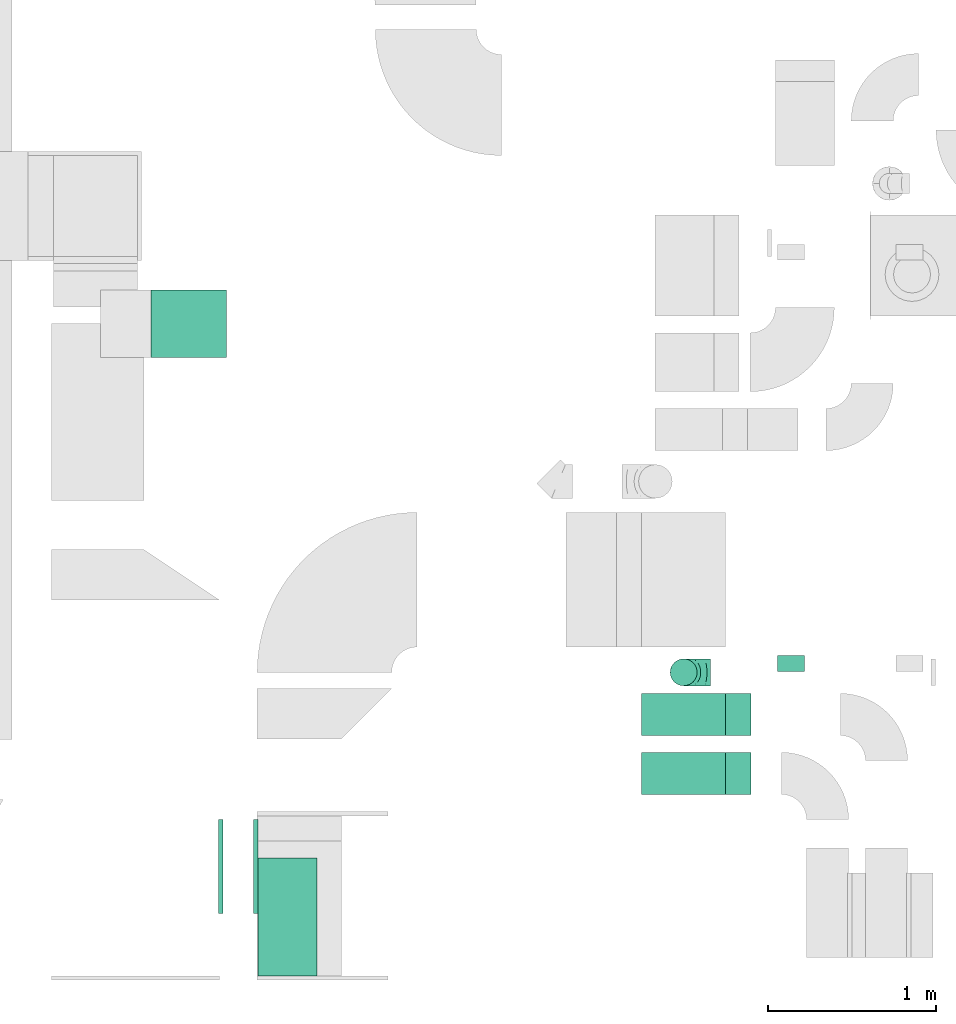
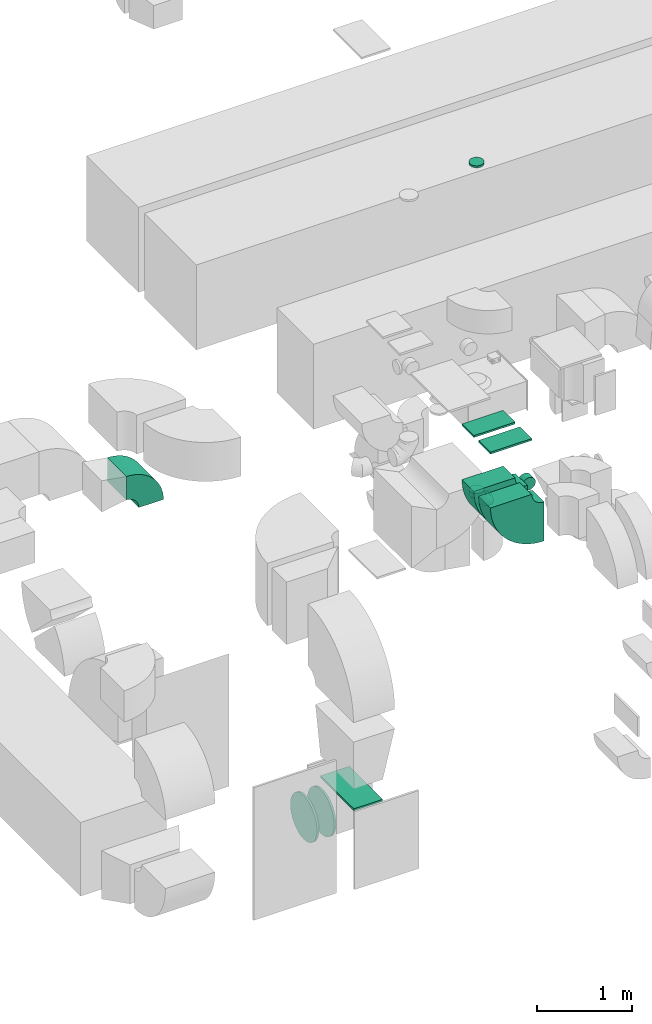
# One storey, part 7 of 59: 11 flow fittings.
"""IFC2X3 building model written with IfcOpenShell, lengths in millimetres."""

import ifcopenshell
import ifcopenshell.guid

model = None  # the IFC model being written
_history = None  # IfcOwnerHistory: only IFC2X3 demands one
_inside = {}  # id of a spatial element -> (the spatial element, [elements in it])
_under = {}  # id of a project, library or spatial element -> (it, [spatial elements below it])
_declared = {}  # id of a project -> (the project, [libraries it declares])
_typed = {}  # id of a type object -> (the type object, [elements of that type])
_made_of = {}  # id of a material, layer set ... -> (it, [elements and type objects made of it])


def new_model(schema):
    """Start an empty IFC model of exactly this schema.

    Asked for "IFC4X3", IfcOpenShell would pick the latest addendum, in which some entities
    have other attributes; the version numbers below select the first issue.
    IFC2X3 requires an IfcOwnerHistory on every rooted entity: one is made here for all.
    """
    global model, _history
    if schema == "IFC4X3":
        model = ifcopenshell.file(schema_version=(4, 3, 0, 0))
    else:
        model = ifcopenshell.file(schema=schema)
    _inside.clear()
    _under.clear()
    _declared.clear()
    _typed.clear()
    _made_of.clear()
    _history = None
    if model.schema == "IFC2X3":
        org = make("IfcOrganization", Name="unknown")
        user = make(
            "IfcPersonAndOrganization",
            ThePerson=make("IfcPerson", FamilyName="unknown"),
            TheOrganization=org,
        )
        app = make(
            "IfcApplication",
            ApplicationDeveloper=org,
            Version="unknown",
            ApplicationFullName="unknown",
            ApplicationIdentifier="unknown",
        )
        _history = make(
            "IfcOwnerHistory",
            OwningUser=user,
            OwningApplication=app,
            ChangeAction="ADDED",
            CreationDate=0,
        )
    return model


def make(cls, **values):
    """One entity of the class cls with the attributes given. An attribute that is None is left unset."""
    return model.create_entity(
        cls, **{name: value for name, value in values.items() if value is not None}
    )


def entity(cls, *values):
    """Any entity or typed value of the class cls, its attributes in the order of the schema. None: left unset."""
    e = model.create_entity(cls)
    for i, value in enumerate(values):
        if value is not None:
            e[i] = value
    return e


def rooted(cls, **values):
    """An entity with a GlobalId (a new one), such as an element, a storey or a relation."""
    return make(cls, GlobalId=ifcopenshell.guid.new(), OwnerHistory=_history, **values)


def si_unit(unit_type, name, prefix=None):
    """IfcSIUnit, for example si_unit("LENGTHUNIT", "METRE", prefix="MILLI")."""
    return make("IfcSIUnit", UnitType=unit_type, Prefix=prefix, Name=name)


def converted_unit(unit_type, name, factor, base, dimensions=None, offset=None):
    """IfcConversionBasedUnit, such as the inch: factor (a typed value) times the base unit."""
    return make(
        "IfcConversionBasedUnit"
        if offset is None
        else "IfcConversionBasedUnitWithOffset",
        ConversionOffset=offset,
        Dimensions=None
        if dimensions is None
        else entity("IfcDimensionalExponents", *dimensions),
        UnitType=unit_type,
        Name=name,
        ConversionFactor=make(
            "IfcMeasureWithUnit", ValueComponent=factor, UnitComponent=base
        ),
    )


def derived_unit(unit_type, elements):
    """IfcDerivedUnit: a product of units, each with its exponent."""
    return make(
        "IfcDerivedUnit",
        Elements=[
            make("IfcDerivedUnitElement", Unit=unit, Exponent=power)
            for unit, power in elements
        ],
        UnitType=unit_type,
    )


def assignment(units):
    """IfcUnitAssignment: the units of a project."""
    return None if units is None else make("IfcUnitAssignment", Units=units)


def point(xyz):
    """IfcCartesianPoint."""
    return None if xyz is None else make("IfcCartesianPoint", Coordinates=xyz)


def direction(xyz):
    """IfcDirection."""
    return None if xyz is None else make("IfcDirection", DirectionRatios=xyz)


def frame(location, z_axis=None, x_axis=None):
    """IfcAxis2Placement3D, a coordinate frame: its origin and axes. An axis left out is left unset."""
    return make(
        "IfcAxis2Placement3D",
        Location=point(location),
        Axis=direction(z_axis),
        RefDirection=direction(x_axis),
    )


def frame_2d(location, x_axis=None):
    """IfcAxis2Placement2D, a coordinate frame in the plane: its origin and x axis."""
    return make(
        "IfcAxis2Placement2D", Location=point(location), RefDirection=direction(x_axis)
    )


def origin():
    """The frame at (0, 0, 0) with its axes left unset."""
    return frame((0.0, 0.0, 0.0))


def origin_2d_with_axis():
    """The frame at (0, 0) in the plane with the x axis (1, 0) written out."""
    return frame_2d((0.0, 0.0), x_axis=(1.0, 0.0))


def place(relative_to, where):
    """IfcLocalPlacement: puts the frame where relative to a parent placement (None: the world)."""
    return make(
        "IfcLocalPlacement", PlacementRelTo=relative_to, RelativePlacement=where
    )


def context(
    kind, dimensions, precision=None, world=None, true_north=None, identifier=None
):
    """IfcGeometricRepresentationContext, for example the 3D "Model" context."""
    return make(
        "IfcGeometricRepresentationContext",
        ContextIdentifier=identifier,
        ContextType=kind,
        CoordinateSpaceDimension=dimensions,
        Precision=precision,
        WorldCoordinateSystem=world,
        TrueNorth=true_north,
    )


def subcontext(parent, identifier, kind, view, scale=None):
    """IfcGeometricRepresentationSubContext, for example "Body" below "Model"."""
    return make(
        "IfcGeometricRepresentationSubContext",
        ContextIdentifier=identifier,
        ContextType=kind,
        ParentContext=parent,
        TargetScale=scale,
        TargetView=view,
    )


def project(units=None, contexts=None):
    """IfcProject with its units and contexts."""
    return rooted(
        "IfcProject",
        Name="project",
        RepresentationContexts=contexts,
        UnitsInContext=assignment(units),
    )


def spatial(cls, under=None, at=None, **own):
    """A site, building, storey or space (cls), placed at a placement, below another one or the project."""
    s = rooted(cls, ObjectPlacement=at, **own)
    if under is not None:
        _under.setdefault(under.id(), (under, []))[1].append(s)
    return s


def polyline(points):
    """IfcPolyline through the points."""
    return make("IfcPolyline", Points=[point(p) for p in points])


def circle_curve(where, radius):
    """IfcCircle in the frame where."""
    return make("IfcCircle", Position=where, Radius=radius)


def parameter(value):
    """IfcParameterValue: where a trimmed curve begins or ends, as a parameter of its basis curve."""
    return model.create_entity("IfcParameterValue", value)


def trimmed(basis, trim1, trim2, sense, master):
    """IfcTrimmedCurve: the piece of a basis curve between two trims."""
    return make(
        "IfcTrimmedCurve",
        BasisCurve=basis,
        Trim1=trim1,
        Trim2=trim2,
        SenseAgreement=sense,
        MasterRepresentation=master,
    )


def segment(curve, same_sense, transition):
    """IfcCompositeCurveSegment."""
    return make(
        "IfcCompositeCurveSegment",
        Transition=transition,
        SameSense=same_sense,
        ParentCurve=curve,
    )


def composite_curve(segments, self_intersect=None):
    """IfcCompositeCurve: segments joined end to end."""
    return make("IfcCompositeCurve", Segments=segments, SelfIntersect=self_intersect)


def profile(cls, at=None, kind="AREA", **sizes):
    """A parametric profile (cls). Its sizes go by their IFC names, for example OverallWidth=200.0."""
    return make(cls, ProfileType=kind, Position=at, **sizes)


def rectangle(**sizes):
    """IfcRectangleProfileDef."""
    return profile("IfcRectangleProfileDef", **sizes)


def circle(**sizes):
    """IfcCircleProfileDef."""
    return profile("IfcCircleProfileDef", **sizes)


def outline(outer, holes=None, kind="AREA"):
    """IfcArbitraryClosedProfileDef: a profile drawn as a closed curve; with holes, ...WithVoids."""
    if holes is None:
        return make("IfcArbitraryClosedProfileDef", ProfileType=kind, OuterCurve=outer)
    return make(
        "IfcArbitraryProfileDefWithVoids",
        ProfileType=kind,
        OuterCurve=outer,
        InnerCurves=holes,
    )


def extrude(swept, where, along, depth):
    """IfcExtrudedAreaSolid: the profile swept, set in the frame where, extruded along a direction by depth."""
    return make(
        "IfcExtrudedAreaSolid",
        SweptArea=swept,
        Position=where,
        ExtrudedDirection=direction(along),
        Depth=depth,
    )


def faces_of(points, faces, orient=None, outer=None):
    """IfcFace entities. A face is a list of loops; a loop is a list of indices into points, from 0.

    orient and outer hold one flag for each loop. By default every Orientation is true, the
    first loop of a face is its IfcFaceOuterBound and the others are IfcFaceBound.
    """
    made = []
    for i, loops in enumerate(faces):
        bounds = []
        for j, loop in enumerate(loops):
            is_outer = j == 0 if outer is None else outer[i][j]
            bounds.append(
                make(
                    "IfcFaceOuterBound" if is_outer else "IfcFaceBound",
                    Bound=make("IfcPolyLoop", Polygon=[points[k] for k in loop]),
                    Orientation=True if orient is None else orient[i][j],
                )
            )
        made.append(make("IfcFace", Bounds=bounds))
    return made


def faceted_brep(points, faces, orient=None, outer=None, voids=None):
    """IfcFacetedBrep: a solid bounded by flat faces; with voids (closed shells), ...WithVoids."""
    shared = [point(p) for p in points]
    hull = make("IfcClosedShell", CfsFaces=faces_of(shared, faces, orient, outer))
    if voids is None:
        return make("IfcFacetedBrep", Outer=hull)
    return make(
        "IfcFacetedBrepWithVoids",
        Outer=hull,
        Voids=[
            make(cls, CfsFaces=faces_of(shared, fs, o, b)) for cls, fs, o, b in voids
        ],
    )


def shape(context_of_items, identifier, shape_type, items):
    """IfcShapeRepresentation: the items that make up one representation, for example the "Body"."""
    return make(
        "IfcShapeRepresentation",
        ContextOfItems=context_of_items,
        RepresentationIdentifier=identifier,
        RepresentationType=shape_type,
        Items=items,
    )


def source(mapping_origin, context_of_items, identifier, shape_type, items):
    """IfcRepresentationMap: a shape defined once, which mapped items show again and again."""
    return make(
        "IfcRepresentationMap",
        MappingOrigin=mapping_origin,
        MappedRepresentation=shape(context_of_items, identifier, shape_type, items),
    )


def transform(
    local_origin,
    x_axis=None,
    y_axis=None,
    z_axis=None,
    scale=None,
    scale2=None,
    scale3=None,
    uniform=True,
):
    """IfcCartesianTransformationOperator3D, or its non-uniform kind. x_axis, y_axis, z_axis: its Axis1, 2, 3."""
    if uniform:
        return make(
            "IfcCartesianTransformationOperator3D",
            Axis1=direction(x_axis),
            Axis2=direction(y_axis),
            LocalOrigin=point(local_origin),
            Scale=scale,
            Axis3=direction(z_axis),
        )
    return make(
        "IfcCartesianTransformationOperator3DnonUniform",
        Axis1=direction(x_axis),
        Axis2=direction(y_axis),
        LocalOrigin=point(local_origin),
        Scale=scale,
        Axis3=direction(z_axis),
        Scale2=scale2,
        Scale3=scale3,
    )


def mapped(mapping_source, mapping_target):
    """IfcMappedItem: shows the shape of a source again, moved by a transform."""
    return make(
        "IfcMappedItem", MappingSource=mapping_source, MappingTarget=mapping_target
    )


def material(Name=None, Category=None):
    """IfcMaterial."""
    return make("IfcMaterial", Name=Name, Category=Category)


def made_of(thing, what):
    """Note that an element or type object is made of a material, layer set ...; save() writes the relation."""
    if what is not None:
        _made_of.setdefault(what.id(), (what, []))[1].append(thing)
    return thing


def type_object(cls, material=None, **own):
    """A type object (cls), such as IfcWallType, which elements share."""
    return made_of(rooted(cls, **own), material)


def type_shapes(of_type, sources):
    """Give a type object the sources (RepresentationMaps) that its elements show as mapped items."""
    of_type.RepresentationMaps = sources


def element(
    cls,
    number,
    at=None,
    inside=None,
    cuts=None,
    type_object=None,
    material=None,
    context=None,
    identifier="Body",
    shape_type=None,
    held_by="IfcProductDefinitionShape",
    body=None,
    shapes=None,
    **own,
):
    """One element of the class cls, such as IfcWall. Its Tag is "e" and its number.

    at: its placement. inside: the storey or other place that contains it. cuts: it is an
    opening in that element (IfcRelVoidsElement). A single representation is given by context,
    identifier, shape_type and body (its items); several are given by shapes. held_by: the class
    of the entity that holds the representations. save() writes the other relations.
    """
    e = rooted(cls, Tag="e%d" % number, ObjectPlacement=at, **own)
    if body is not None:
        shapes = [shape(context, identifier, shape_type, body)]
    if shapes is not None:
        e.Representation = make(held_by, Representations=shapes)
    if inside is not None:
        _inside.setdefault(inside.id(), (inside, []))[1].append(e)
    if cuts is not None:
        rooted(
            "IfcRelVoidsElement", RelatingBuildingElement=cuts, RelatedOpeningElement=e
        )
    if type_object is not None:
        _typed.setdefault(type_object.id(), (type_object, []))[1].append(e)
    return made_of(e, material)


def aggregate(whole, parts):
    """IfcRelAggregates: a whole, such as a stair, and the parts it consists of."""
    return rooted("IfcRelAggregates", RelatingObject=whole, RelatedObjects=parts)


def save(model, path):
    """Write the relations noted so far, then the file.

    IfcRelAggregates (storeys below a building ...), IfcRelContainedInSpatialStructure (elements
    in a storey), IfcRelDefinesByType, IfcRelAssociatesMaterial and IfcRelDeclares: one each for
    every whole, place, type object, material and project.
    """
    for whole, parts in _under.values():
        aggregate(whole, parts)
    for where, things in _inside.values():
        rooted(
            "IfcRelContainedInSpatialStructure",
            RelatedElements=things,
            RelatingStructure=where,
        )
    for kind, things in _typed.values():
        rooted("IfcRelDefinesByType", RelatedObjects=things, RelatingType=kind)
    for what, things in _made_of.values():
        rooted("IfcRelAssociatesMaterial", RelatedObjects=things, RelatingMaterial=what)
    for by, libraries in _declared.values():
        rooted("IfcRelDeclares", RelatingContext=by, RelatedDefinitions=libraries)
    model.write(path)


model = new_model("IFC2X3")

# Units and contexts
model_context = context("Model", 3, precision=0.01, world=origin(), true_north=direction((6.12303176911189e-17, 1.0)))
body_context = subcontext(model_context, "Body", "Model", "MODEL_VIEW")
ifc_project = project(units=[si_unit("LENGTHUNIT", "METRE", prefix="MILLI"), si_unit("AREAUNIT", "SQUARE_METRE"), si_unit("VOLUMEUNIT", "CUBIC_METRE"), converted_unit("PLANEANGLEUNIT", "DEGREE", entity("IfcRatioMeasure", 0.0174532925199433), si_unit("PLANEANGLEUNIT", "RADIAN"), dimensions=[0, 0, 0, 0, 0, 0, 0]), si_unit("MASSUNIT", "GRAM", prefix="KILO"), derived_unit("MASSDENSITYUNIT", [(si_unit("MASSUNIT", "GRAM", prefix="KILO"), 1), (si_unit("LENGTHUNIT", "METRE"), -3)]), derived_unit("MOMENTOFINERTIAUNIT", [(si_unit("LENGTHUNIT", "METRE"), 4)]), si_unit("TIMEUNIT", "SECOND"), si_unit("FREQUENCYUNIT", "HERTZ"), si_unit("THERMODYNAMICTEMPERATUREUNIT", "DEGREE_CELSIUS"), derived_unit("THERMALTRANSMITTANCEUNIT", [(si_unit("MASSUNIT", "GRAM", prefix="KILO"), 1), (si_unit("THERMODYNAMICTEMPERATUREUNIT", "KELVIN"), -1), (si_unit("TIMEUNIT", "SECOND"), -3)]), derived_unit("VOLUMETRICFLOWRATEUNIT", [(si_unit("LENGTHUNIT", "METRE"), 3), (si_unit("TIMEUNIT", "SECOND"), -1)]), derived_unit("MASSFLOWRATEUNIT", [(si_unit("MASSUNIT", "GRAM", prefix="KILO"), 1), (si_unit("TIMEUNIT", "SECOND"), -1)]), derived_unit("ROTATIONALFREQUENCYUNIT", [(si_unit("TIMEUNIT", "SECOND"), -1)]), si_unit("ELECTRICCURRENTUNIT", "AMPERE"), si_unit("ELECTRICVOLTAGEUNIT", "VOLT"), si_unit("POWERUNIT", "WATT"), si_unit("FORCEUNIT", "NEWTON", prefix="KILO"), si_unit("ILLUMINANCEUNIT", "LUX"), si_unit("LUMINOUSFLUXUNIT", "LUMEN"), si_unit("LUMINOUSINTENSITYUNIT", "CANDELA"), derived_unit("USERDEFINED", [(si_unit("MASSUNIT", "GRAM", prefix="KILO"), -1), (si_unit("LENGTHUNIT", "METRE"), -2), (si_unit("TIMEUNIT", "SECOND"), 3), (si_unit("LUMINOUSFLUXUNIT", "LUMEN"), 1)]), derived_unit("LINEARVELOCITYUNIT", [(si_unit("LENGTHUNIT", "METRE"), 1), (si_unit("TIMEUNIT", "SECOND"), -1)]), si_unit("PRESSUREUNIT", "PASCAL"), derived_unit("USERDEFINED", [(si_unit("LENGTHUNIT", "METRE"), -2), (si_unit("MASSUNIT", "GRAM", prefix="KILO"), 1), (si_unit("TIMEUNIT", "SECOND"), -2)]), derived_unit("LINEARFORCEUNIT", [(si_unit("MASSUNIT", "GRAM", prefix="KILO"), 1), (si_unit("LENGTHUNIT", "METRE"), 1), (si_unit("TIMEUNIT", "SECOND"), -2), (si_unit("LENGTHUNIT", "METRE"), -1)]), derived_unit("PLANARFORCEUNIT", [(si_unit("MASSUNIT", "GRAM", prefix="KILO"), 1), (si_unit("LENGTHUNIT", "METRE"), 1), (si_unit("TIMEUNIT", "SECOND"), -2), (si_unit("LENGTHUNIT", "METRE"), -2)])], contexts=[model_context])

# Site, building, storey
site_placement = place(None, origin())
site = spatial("IfcSite", under=ifc_project, at=site_placement, CompositionType="ELEMENT")
building_placement = place(site_placement, origin())
building = spatial("IfcBuilding", under=site, at=building_placement, CompositionType="ELEMENT")
storey_placement = place(building_placement, frame((0.0, 0.0, 28200.0)))
storey = spatial("IfcBuildingStorey", under=building, at=storey_placement, CompositionType="ELEMENT", Elevation=28200.0)

# Flow fittings
ifc_material = material()
duct_fitting_type_1 = type_object("IfcDuctFittingType", PredefinedType="NOTDEFINED", material=ifc_material)
shared_shape_1 = source(origin(), body_context, "Body", "SweptSolid", [
    extrude(circle(Radius=79.9999999999994, at=origin_2d_with_axis()), frame((0.0, 0.0, 0.0), z_axis=(1.0, 0.0, 0.0), x_axis=(0.0, 1.0, 0.0)), (0.0, 0.0, 1.0), 25.0000000000018),
])
type_shapes(duct_fitting_type_1, [shared_shape_1])
flow_fitting_1_placement = place(storey_placement, frame((27824.64, 9627.84, 7540.0), z_axis=(1.0, 0.0, 0.0), x_axis=(0.0, 0.0, 1.0)))
element("IfcFlowFitting", 1, at=flow_fitting_1_placement, inside=storey, type_object=duct_fitting_type_1, material=ifc_material, context=body_context, shape_type="MappedRepresentation", body=[
    mapped(shared_shape_1, transform((0.0, 0.0, 0.0), scale=1.0)),
])
duct_fitting_type_2 = type_object("IfcDuctFittingType", PredefinedType="NOTDEFINED", material=ifc_material)
shared_shape_2 = source(origin(), body_context, "Body", "SweptSolid", [
    extrude(rectangle(XDim=26.0960000000872, YDim=350.0, at=origin_2d_with_axis()), frame((6.95, 0.0, -350.0)), (0.0, 0.0, 1.0), 700.0),
])
type_shapes(duct_fitting_type_2, [shared_shape_2])
flow_fitting_2_placement = place(storey_placement, frame((25470.29, 8174.6, 1225.0), z_axis=(0.0, -1.0, 0.0), x_axis=(0.0, 0.0, 1.0)))
element("IfcFlowFitting", 2, at=flow_fitting_2_placement, inside=storey, type_object=duct_fitting_type_2, material=ifc_material, context=body_context, shape_type="MappedRepresentation", body=[
    mapped(shared_shape_2, transform((0.0, 0.0, 0.0), scale=1.0)),
])
duct_fitting_type_3 = type_object("IfcDuctFittingType", PredefinedType="NOTDEFINED", material=ifc_material)
shared_shape_3 = source(origin(), body_context, "Body", "SweptSolid", [
    extrude(rectangle(XDim=24.9999999999999, YDim=250.0, at=origin_2d_with_axis()), frame((12.5, 0.0, -250.0)), (0.0, 0.0, 1.0), 500.0),
])
type_shapes(duct_fitting_type_3, [shared_shape_3])
for number, where, z_axis, x_axis in (
    (3, (27824.64, 9377.5, 4340.0), (1.0, 0.0, 0.0), (0.0, 0.0, 1.0)),
    (4, (27824.64, 9027.5, 4340.0), (1.0, 0.0, 0.0), (0.0, 0.0, 1.0)),
):
    element("IfcFlowFitting", number, at=place(storey_placement, frame(where, z_axis=z_axis, x_axis=x_axis)), inside=storey, type_object=duct_fitting_type_3, material=ifc_material, context=body_context, shape_type="MappedRepresentation", body=[
        mapped(shared_shape_3, transform((0.0, 0.0, 0.0), scale=1.0)),
    ])
duct_fitting_type_4 = type_object("IfcDuctFittingType", PredefinedType="NOTDEFINED", material=ifc_material)
shared_shape_4 = source(origin(), body_context, "Body", "Brep", [
    faceted_brep([(-160.0, 0.0, -80.0), (-160.0, -20.71, -77.27), (-160.0, -40.0, -69.28), (-160.0, -56.57, -56.57), (-160.0, -69.28, -40.0), (-160.0, -77.27, -20.71), (-160.0, -80.0, 0.0), (-160.0, -77.27, 20.71), (-160.0, -69.28, 40.0), (-160.0, -56.57, 56.57), (-160.0, -40.0, 69.28), (-160.0, -20.71, 77.27), (-160.0, 0.0, 80.0), (-160.0, 20.71, 77.27), (-160.0, 40.0, 69.28), (-160.0, 56.57, 56.57), (-160.0, 69.28, 40.0), (-160.0, 77.27, 20.71), (-160.0, 80.0, 0.0), (-160.0, 77.27, -20.71), (-160.0, 69.28, -40.0), (-160.0, 56.57, -56.57), (-160.0, 40.0, -69.28), (-160.0, 20.71, -77.27), (-122.68, 20.71, 77.27), (-127.85, 40.0, 69.28), (-117.13, 0.0, 80.0), (-132.29, 56.57, 56.57), (-137.83, 77.27, 20.71), (-138.56, 80.0, 0.0), (-135.69, 69.28, 40.0), (-135.69, 69.28, -40.0), (-132.29, 56.57, -56.57), (-137.83, 77.27, -20.71), (-122.68, 20.71, -77.27), (-117.13, 0.0, -80.0), (-127.85, 40.0, -69.28), (-111.58, -20.71, -77.27), (-106.41, -40.0, -69.28), (-101.97, -56.57, -56.57), (-98.56, -69.28, -40.0), (-96.42, -77.27, -20.71), (-95.69, -80.0, 0.0), (-96.42, -77.27, 20.71), (-98.56, -69.28, 40.0), (-101.97, -56.57, 56.57), (-106.41, -40.0, 69.28), (-111.58, -20.71, 77.27), (-58.03, 58.03, 77.27), (-72.15, 72.15, 69.28), (-42.87, 42.87, 80.0), (-84.28, 84.28, 56.57), (-93.59, 93.59, 40.0), (-99.44, 99.44, 20.71), (-101.44, 101.44, 0.0), (-99.44, 99.44, -20.71), (-93.59, 93.59, -40.0), (-84.28, 84.28, -56.57), (-58.03, 58.03, -77.27), (-42.87, 42.87, -80.0), (-72.15, 72.15, -69.28), (-27.71, 27.71, -77.27), (-13.59, 13.59, -69.28), (-1.46, 1.46, -56.57), (7.85, -7.85, -40.0), (13.7, -13.7, -20.71), (15.69, -15.69, 0.0), (13.7, -13.7, 20.71), (7.85, -7.85, 40.0), (-1.46, 1.46, 56.57), (-13.59, 13.59, 69.28), (-27.71, 27.71, 77.27), (-20.71, 122.68, 77.27), (-40.0, 127.85, 69.28), (0.0, 117.13, 80.0), (-56.57, 132.29, 56.57), (-69.28, 135.69, 40.0), (-77.27, 137.83, 20.71), (-80.0, 138.56, 0.0), (-77.27, 137.83, -20.71), (-69.28, 135.69, -40.0), (-56.57, 132.29, -56.57), (-20.71, 122.68, -77.27), (0.0, 117.13, -80.0), (-40.0, 127.85, -69.28), (20.71, 111.58, -77.27), (40.0, 106.41, -69.28), (56.57, 101.97, -56.57), (69.28, 98.56, -40.0), (77.27, 96.42, -20.71), (80.0, 95.69, 0.0), (77.27, 96.42, 20.71), (69.28, 98.56, 40.0), (56.57, 101.97, 56.57), (40.0, 106.41, 69.28), (20.71, 111.58, 77.27), (-20.71, 160.0, -77.27), (-40.0, 160.0, -69.28), (-56.57, 160.0, -56.57), (-69.28, 160.0, -40.0), (-77.27, 160.0, -20.71), (-80.0, 160.0, 0.0), (-77.27, 160.0, 20.71), (-69.28, 160.0, 40.0), (-56.57, 160.0, 56.57), (-40.0, 160.0, 69.28), (-20.71, 160.0, 77.27), (0.0, 160.0, 80.0), (20.71, 160.0, 77.27), (40.0, 160.0, 69.28), (56.57, 160.0, 56.57), (69.28, 160.0, 40.0), (77.27, 160.0, 20.71), (80.0, 160.0, 0.0), (77.27, 160.0, -20.71), (69.28, 160.0, -40.0), (56.57, 160.0, -56.57), (40.0, 160.0, -69.28), (20.71, 160.0, -77.27), (0.0, 160.0, -80.0)], [[[0, 1, 2, 3, 4, 5, 6, 7, 8, 9, 10, 11, 12, 13, 14, 15, 16, 17, 18, 19, 20, 21, 22, 23]], [[24, 25, 14, 13]], [[26, 24, 13, 12]], [[14, 25, 27, 15]], [[28, 29, 18, 17]], [[30, 28, 17, 16]], [[15, 27, 30, 16]], [[20, 31, 32, 21]], [[33, 31, 20, 19]], [[18, 29, 33, 19]], [[34, 35, 0, 23]], [[36, 34, 23, 22]], [[32, 36, 22, 21]], [[1, 0, 35, 37]], [[2, 1, 37, 38]], [[3, 2, 38, 39]], [[5, 4, 40, 41]], [[6, 5, 41, 42]], [[39, 40, 4, 3]], [[6, 42, 43, 7]], [[7, 43, 44, 8]], [[8, 44, 45, 9]], [[9, 45, 46, 10]], [[10, 46, 47, 11]], [[26, 12, 11, 47]], [[48, 49, 25, 24]], [[50, 48, 24, 26]], [[27, 25, 49, 51]], [[52, 53, 28, 30]], [[51, 52, 30, 27]], [[29, 28, 53, 54]], [[55, 56, 31, 33]], [[54, 55, 33, 29]], [[32, 31, 56, 57]], [[58, 59, 35, 34]], [[60, 58, 34, 36]], [[57, 60, 36, 32]], [[37, 35, 59, 61]], [[38, 37, 61, 62]], [[39, 38, 62, 63]], [[41, 40, 64, 65]], [[42, 41, 65, 66]], [[63, 64, 40, 39]], [[43, 42, 66, 67]], [[44, 43, 67, 68]], [[68, 69, 45, 44]], [[46, 45, 69, 70]], [[47, 46, 70, 71]], [[26, 47, 71, 50]], [[72, 73, 49, 48]], [[74, 72, 48, 50]], [[51, 49, 73, 75]], [[76, 77, 53, 52]], [[75, 76, 52, 51]], [[54, 53, 77, 78]], [[79, 80, 56, 55]], [[78, 79, 55, 54]], [[57, 56, 80, 81]], [[82, 83, 59, 58]], [[84, 82, 58, 60]], [[81, 84, 60, 57]], [[61, 59, 83, 85]], [[62, 61, 85, 86]], [[63, 62, 86, 87]], [[65, 64, 88, 89]], [[66, 65, 89, 90]], [[87, 88, 64, 63]], [[67, 66, 90, 91]], [[68, 67, 91, 92]], [[92, 93, 69, 68]], [[70, 69, 93, 94]], [[71, 70, 94, 95]], [[50, 71, 95, 74]], [[96, 97, 98, 99, 100, 101, 102, 103, 104, 105, 106, 107, 108, 109, 110, 111, 112, 113, 114, 115, 116, 117, 118, 119]], [[72, 74, 107, 106]], [[73, 72, 106, 105]], [[75, 73, 105, 104]], [[77, 76, 103, 102]], [[78, 77, 102, 101]], [[75, 104, 103, 76]], [[78, 101, 100, 79]], [[79, 100, 99, 80]], [[80, 99, 98, 81]], [[84, 97, 96, 82]], [[82, 96, 119, 83]], [[84, 81, 98, 97]], [[118, 117, 86, 85]], [[119, 118, 85, 83]], [[116, 87, 86, 117]], [[88, 115, 114, 89]], [[89, 114, 113, 90]], [[115, 88, 87, 116]], [[112, 111, 92, 91]], [[113, 112, 91, 90]], [[111, 110, 93, 92]], [[95, 94, 109, 108]], [[74, 95, 108, 107]], [[110, 109, 94, 93]]]),
])
type_shapes(duct_fitting_type_4, [shared_shape_4])
flow_fitting_3_placement = place(storey_placement, frame((27824.64, 9627.84, 3205.01), z_axis=(0.0, -1.0, 0.0), x_axis=(0.0, 0.0, -1.0)))
element("IfcFlowFitting", 5, at=flow_fitting_3_placement, inside=storey, type_object=duct_fitting_type_4, material=ifc_material, context=body_context, shape_type="MappedRepresentation", body=[
    mapped(shared_shape_4, transform((0.0, 0.0, 0.0), scale=1.0)),
])
duct_fitting_type_5 = type_object("IfcDuctFittingType", PredefinedType="NOTDEFINED", material=ifc_material)
shared_shape_5 = source(origin(), body_context, "Body", "Brep", [
    faceted_brep([(20.0, 20.71, -77.27), (20.0, 40.0, -69.28), (20.0, 56.57, -56.57), (20.0, 69.28, -40.0), (20.0, 77.27, -20.71), (20.0, 80.0, 0.0), (20.0, 77.27, 20.71), (20.0, 69.28, 40.0), (20.0, 56.57, 56.57), (20.0, 40.0, 69.28), (20.0, 20.71, 77.27), (20.0, 0.0, 80.0), (20.0, -20.71, 77.27), (20.0, -40.0, 69.28), (20.0, -56.57, 56.57), (20.0, -69.28, 40.0), (20.0, -77.27, 20.71), (20.0, -80.0, 0.0), (20.0, -77.27, -20.71), (20.0, -69.28, -40.0), (20.0, -56.57, -56.57), (20.0, -40.0, -69.28), (20.0, -20.71, -77.27), (20.0, 0.0, -80.0), (0.0, 0.0, 80.0), (0.0, 20.71, 77.27), (-73.9, 20.71, 77.27), (-73.9, 0.0, 80.0), (0.0, 40.0, 69.28), (-73.9, 40.0, 69.28), (0.0, 56.57, 56.57), (-73.9, 56.57, 56.57), (0.0, 69.28, 40.0), (0.0, 77.27, 20.71), (-73.9, 77.27, 20.71), (-73.9, 69.28, 40.0), (0.0, 80.0, 0.0), (-73.9, 80.0, 0.0), (0.0, 77.27, -20.71), (-73.9, 77.27, -20.71), (0.0, 69.28, -40.0), (-73.9, 69.28, -40.0), (0.0, 56.57, -56.57), (-73.9, 56.57, -56.57), (0.0, 40.0, -69.28), (0.0, 20.71, -77.27), (-73.9, 20.71, -77.27), (-73.9, 40.0, -69.28), (0.0, 0.0, -80.0), (-73.9, 0.0, -80.0), (0.0, -20.71, -77.27), (-73.9, -20.71, -77.27), (0.0, -40.0, -69.28), (-73.9, -40.0, -69.28), (0.0, -56.57, -56.57), (-73.9, -56.57, -56.57), (0.0, -69.28, -40.0), (0.0, -77.27, -20.71), (-73.9, -77.27, -20.71), (-73.9, -69.28, -40.0), (0.0, -80.0, 0.0), (-73.9, -80.0, 0.0), (0.0, -77.27, 20.71), (-73.9, -77.27, 20.71), (0.0, -69.28, 40.0), (-73.9, -69.28, 40.0), (0.0, -56.57, 56.57), (-73.9, -56.57, 56.57), (0.0, -40.0, 69.28), (0.0, -20.71, 77.27), (-73.9, -20.71, 77.27), (-73.9, -40.0, 69.28)], [[[0, 1, 2, 3, 4, 5, 6, 7, 8, 9, 10, 11, 12, 13, 14, 15, 16, 17, 18, 19, 20, 21, 22, 23]], [[24, 11, 10, 25, 26, 27]], [[25, 10, 9, 28, 29, 26]], [[28, 9, 8, 30, 31, 29]], [[32, 7, 6, 33, 34, 35]], [[33, 6, 5, 36, 37, 34]], [[30, 8, 7, 32, 35, 31]], [[36, 5, 4, 38, 39, 37]], [[38, 4, 3, 40, 41, 39]], [[40, 3, 2, 42, 43, 41]], [[44, 1, 0, 45, 46, 47]], [[45, 0, 23, 48, 49, 46]], [[42, 2, 1, 44, 47, 43]], [[48, 23, 22, 50, 51, 49]], [[50, 22, 21, 52, 53, 51]], [[52, 21, 20, 54, 55, 53]], [[56, 19, 18, 57, 58, 59]], [[57, 18, 17, 60, 61, 58]], [[54, 20, 19, 56, 59, 55]], [[60, 17, 16, 62, 63, 61]], [[62, 16, 15, 64, 65, 63]], [[64, 15, 14, 66, 67, 65]], [[68, 13, 12, 69, 70, 71]], [[69, 12, 11, 24, 27, 70]], [[66, 14, 13, 68, 71, 67]], [[49, 51, 53, 55, 59, 58, 61, 63, 65, 67, 71, 70, 27, 26, 29, 31, 35, 34, 37, 39, 41, 43, 47, 46]]]),
])
type_shapes(duct_fitting_type_5, [shared_shape_5])
flow_fitting_4_placement = place(storey_placement, frame((28463.36, 9707.84, 3205.01), z_axis=(0.0, 0.0, -1.0), x_axis=(0.0, 1.0, 0.0)))
element("IfcFlowFitting", 6, at=flow_fitting_4_placement, inside=storey, type_object=duct_fitting_type_5, material=ifc_material, context=body_context, shape_type="MappedRepresentation", body=[
    mapped(shared_shape_5, transform((0.0, 0.0, 0.0), scale=1.0)),
])
duct_fitting_type_6 = type_object("IfcDuctFittingType", PredefinedType="NOTDEFINED", material=ifc_material)
shared_shape_6 = source(origin(), body_context, "Body", "Brep", [
    faceted_brep([(20.0, -107.15, -258.69), (20.0, -54.63, -274.62), (20.0, 0.0, -280.0), (20.0, 54.63, -274.62), (20.0, 107.15, -258.69), (20.0, 155.56, -232.81), (20.0, 197.99, -197.99), (20.0, 232.81, -155.56), (20.0, 258.69, -107.15), (20.0, 274.62, -54.63), (20.0, 280.0, 0.0), (20.0, 274.62, 54.63), (20.0, 258.69, 107.15), (20.0, 232.81, 155.56), (20.0, 197.99, 197.99), (20.0, 155.56, 232.81), (20.0, 107.15, 258.69), (20.0, 54.63, 274.62), (20.0, 0.0, 280.0), (20.0, -54.63, 274.62), (20.0, -107.15, 258.69), (20.0, -155.56, 232.81), (20.0, -197.99, 197.99), (20.0, -232.81, 155.56), (20.0, -258.69, 107.15), (20.0, -274.62, 54.63), (20.0, -280.0, 0.0), (20.0, -274.62, -54.63), (20.0, -258.69, -107.15), (20.0, -232.81, -155.56), (20.0, -197.99, -197.99), (20.0, -155.56, -232.81), (0.0, 0.0, 280.0), (0.0, -36.28, 276.43), (0.0, -54.63, 274.62), (-6.1, -27.31, 277.31), (-6.1, 0.0, 280.0), (-6.1, -54.63, 274.62), (0.0, -80.89, 266.65), (-6.1, -80.89, 266.65), (0.0, -107.15, 258.69), (-6.1, -107.15, 258.69), (0.0, -131.36, 245.75), (-6.1, -131.36, 245.75), (0.0, -155.56, 232.81), (-6.1, -155.56, 232.81), (0.0, -176.77, 215.4), (0.0, -197.99, 197.99), (-6.1, -176.77, 215.4), (-6.1, -197.99, 197.99), (0.0, -232.81, 155.56), (0.0, -245.75, 131.36), (-6.1, -232.81, 155.56), (-6.1, -245.75, 131.36), (-6.1, -258.69, 107.15), (0.0, -258.69, 107.15), (0.0, -274.62, 54.63), (0.0, -266.65, 80.89), (-6.1, -274.62, 54.63), (-6.1, -266.65, 80.89), (0.0, -280.0, 0.0), (0.0, -276.43, 36.28), (-6.1, -277.31, 27.31), (-6.1, -280.0, 0.0), (0.0, -215.4, 176.77), (-6.1, -215.4, 176.77), (0.0, -276.43, -36.28), (0.0, -274.62, -54.63), (-6.1, -277.31, -27.31), (-6.1, -274.62, -54.63), (0.0, -266.65, -80.89), (-6.1, -266.65, -80.89), (0.0, -258.69, -107.15), (-6.1, -258.69, -107.15), (0.0, -245.75, -131.36), (-6.1, -245.75, -131.36), (0.0, -232.81, -155.56), (-6.1, -232.81, -155.56), (0.0, -215.4, -176.77), (0.0, -197.99, -197.99), (-6.1, -215.4, -176.77), (-6.1, -197.99, -197.99), (0.0, -107.15, -258.69), (0.0, -131.36, -245.75), (0.0, -155.56, -232.81), (-6.1, -131.36, -245.75), (-6.1, -155.56, -232.81), (-6.1, -107.15, -258.69), (0.0, -54.63, -274.62), (0.0, -80.89, -266.65), (-6.1, -80.89, -266.65), (-6.1, -54.63, -274.62), (0.0, 0.0, -280.0), (0.0, -36.28, -276.43), (-6.1, -27.31, -277.31), (-6.1, 0.0, -280.0), (0.0, -176.77, -215.4), (-6.1, -176.77, -215.4), (0.0, 36.28, -276.43), (0.0, 54.63, -274.62), (-6.1, 27.31, -277.31), (-6.1, 54.63, -274.62), (0.0, 80.89, -266.65), (-6.1, 80.89, -266.65), (0.0, 107.15, -258.69), (-6.1, 107.15, -258.69), (0.0, 131.36, -245.75), (-6.1, 131.36, -245.75), (0.0, 155.56, -232.81), (-6.1, 155.56, -232.81), (0.0, 176.77, -215.4), (0.0, 197.99, -197.99), (-6.1, 176.77, -215.4), (-6.1, 197.99, -197.99), (0.0, 258.69, -107.15), (0.0, 245.75, -131.36), (0.0, 232.81, -155.56), (-6.1, 245.75, -131.36), (-6.1, 232.81, -155.56), (-6.1, 258.69, -107.15), (0.0, 274.62, -54.63), (0.0, 266.65, -80.89), (-6.1, 274.62, -54.63), (-6.1, 266.65, -80.89), (0.0, 280.0, 0.0), (0.0, 276.43, -36.28), (-6.1, 277.31, -27.31), (-6.1, 280.0, 0.0), (0.0, 215.4, -176.77), (-6.1, 215.4, -176.77), (0.0, 276.43, 36.28), (0.0, 274.62, 54.63), (-6.1, 277.31, 27.31), (-6.1, 274.62, 54.63), (0.0, 266.65, 80.89), (-6.1, 266.65, 80.89), (0.0, 258.69, 107.15), (-6.1, 258.69, 107.15), (0.0, 245.75, 131.36), (-6.1, 245.75, 131.36), (0.0, 232.81, 155.56), (-6.1, 232.81, 155.56), (0.0, 215.4, 176.77), (0.0, 197.99, 197.99), (-6.1, 215.4, 176.77), (-6.1, 197.99, 197.99), (0.0, 107.15, 258.69), (0.0, 131.36, 245.75), (-6.1, 107.15, 258.69), (0.0, 155.56, 232.81), (-6.1, 131.36, 245.75), (-6.1, 155.56, 232.81), (0.0, 54.63, 274.62), (0.0, 80.89, 266.65), (-6.1, 54.63, 274.62), (-6.1, 80.89, 266.65), (0.0, 36.28, 276.43), (-6.1, 27.31, 277.31), (0.0, 176.77, 215.4), (-6.1, 176.77, 215.4)], [[[0, 1, 2, 3, 4, 5, 6, 7, 8, 9, 10, 11, 12, 13, 14, 15, 16, 17, 18, 19, 20, 21, 22, 23, 24, 25, 26, 27, 28, 29, 30, 31]], [[19, 18, 32]], [[19, 32, 33]], [[19, 33, 34]], [[35, 33, 32]], [[35, 32, 36]], [[35, 37, 33]], [[33, 37, 34]], [[34, 20, 19]], [[20, 34, 38]], [[34, 37, 38]], [[39, 38, 37]], [[40, 38, 39]], [[39, 41, 40]], [[20, 38, 40]], [[20, 40, 21]], [[21, 40, 42]], [[41, 42, 40]], [[43, 42, 41]], [[43, 44, 42]], [[43, 45, 44]], [[21, 42, 44]], [[22, 44, 46]], [[22, 21, 44]], [[22, 46, 47]], [[46, 44, 45]], [[46, 45, 48]], [[47, 48, 49]], [[46, 48, 47]], [[50, 24, 23]], [[24, 50, 51]], [[52, 51, 50]], [[53, 51, 52]], [[51, 53, 54]], [[55, 51, 54]], [[24, 51, 55]], [[56, 25, 24]], [[24, 57, 56]], [[58, 56, 57]], [[24, 55, 57]], [[57, 55, 59]], [[54, 59, 55]], [[59, 58, 57]], [[26, 25, 60]], [[25, 61, 60]], [[25, 56, 61]], [[56, 58, 61]], [[62, 61, 58]], [[62, 63, 60]], [[61, 62, 60]], [[23, 47, 64]], [[22, 47, 23]], [[23, 64, 50]], [[64, 47, 49]], [[49, 65, 64]], [[65, 52, 50]], [[64, 65, 50]], [[27, 26, 60]], [[27, 60, 66]], [[27, 66, 67]], [[68, 66, 60]], [[68, 60, 63]], [[68, 69, 66]], [[66, 69, 67]], [[67, 28, 27]], [[28, 67, 70]], [[67, 69, 70]], [[71, 70, 69]], [[72, 70, 71]], [[71, 73, 72]], [[28, 70, 72]], [[28, 72, 29]], [[29, 72, 74]], [[73, 74, 72]], [[75, 74, 73]], [[75, 76, 74]], [[75, 77, 76]], [[29, 74, 76]], [[30, 76, 78]], [[30, 29, 76]], [[30, 78, 79]], [[78, 76, 77]], [[78, 77, 80]], [[79, 80, 81]], [[78, 80, 79]], [[0, 31, 82]], [[31, 83, 82]], [[31, 84, 83]], [[83, 84, 85]], [[86, 85, 84]], [[85, 87, 83]], [[87, 82, 83]], [[1, 0, 88]], [[0, 89, 88]], [[0, 82, 89]], [[89, 82, 90]], [[87, 90, 82]], [[90, 91, 89]], [[91, 88, 89]], [[2, 1, 92]], [[1, 93, 92]], [[1, 88, 93]], [[88, 91, 93]], [[94, 93, 91]], [[94, 95, 92]], [[93, 94, 92]], [[31, 79, 96]], [[30, 79, 31]], [[31, 96, 84]], [[96, 79, 81]], [[81, 97, 96]], [[97, 86, 96]], [[96, 86, 84]], [[3, 2, 92]], [[3, 92, 98]], [[3, 98, 99]], [[100, 98, 92]], [[100, 92, 95]], [[100, 101, 98]], [[98, 101, 99]], [[99, 4, 3]], [[4, 99, 102]], [[99, 101, 102]], [[103, 102, 101]], [[104, 102, 103]], [[103, 105, 104]], [[4, 102, 104]], [[4, 104, 5]], [[5, 104, 106]], [[105, 106, 104]], [[107, 106, 105]], [[107, 108, 106]], [[107, 109, 108]], [[5, 106, 108]], [[6, 108, 110]], [[6, 5, 108]], [[6, 110, 111]], [[110, 108, 109]], [[110, 109, 112]], [[110, 112, 111]], [[111, 112, 113]], [[8, 7, 114]], [[7, 115, 114]], [[7, 116, 115]], [[115, 116, 117]], [[118, 117, 116]], [[117, 119, 115]], [[119, 114, 115]], [[120, 9, 8]], [[8, 121, 120]], [[122, 120, 121]], [[8, 114, 121]], [[121, 114, 123]], [[119, 123, 114]], [[123, 122, 121]], [[9, 124, 10]], [[9, 125, 124]], [[9, 120, 125]], [[120, 122, 125]], [[126, 125, 122]], [[126, 127, 124]], [[125, 126, 124]], [[6, 111, 128]], [[6, 128, 116]], [[7, 6, 116]], [[111, 113, 128]], [[129, 128, 113]], [[129, 118, 128]], [[128, 118, 116]], [[11, 10, 124]], [[11, 124, 130]], [[11, 130, 131]], [[132, 130, 124]], [[132, 124, 127]], [[132, 133, 130]], [[130, 133, 131]], [[131, 12, 11]], [[12, 131, 134]], [[131, 133, 134]], [[135, 134, 133]], [[136, 134, 135]], [[135, 137, 136]], [[12, 134, 136]], [[12, 136, 13]], [[13, 136, 138]], [[137, 138, 136]], [[139, 138, 137]], [[139, 140, 138]], [[139, 141, 140]], [[13, 138, 140]], [[14, 140, 142]], [[14, 13, 140]], [[14, 142, 143]], [[142, 140, 141]], [[142, 141, 144]], [[142, 144, 143]], [[143, 144, 145]], [[146, 16, 15]], [[15, 147, 146]], [[148, 146, 147]], [[15, 149, 147]], [[147, 149, 150]], [[151, 150, 149]], [[150, 148, 147]], [[152, 17, 16]], [[16, 153, 152]], [[154, 152, 153]], [[16, 146, 153]], [[153, 146, 155]], [[148, 155, 146]], [[155, 154, 153]], [[18, 17, 32]], [[17, 156, 32]], [[17, 152, 156]], [[152, 154, 156]], [[157, 156, 154]], [[157, 36, 32]], [[156, 157, 32]], [[14, 143, 158]], [[14, 158, 149]], [[15, 14, 149]], [[158, 143, 145]], [[159, 158, 145]], [[159, 151, 158]], [[149, 158, 151]], [[63, 62, 58, 59, 54, 53, 52, 65, 49, 48, 45, 43, 41, 39, 37, 35, 36, 157, 154, 155, 148, 150, 151, 159, 145, 144, 141, 139, 137, 135, 133, 132, 127, 126, 122, 123, 119, 117, 118, 129, 113, 112, 109, 107, 105, 103, 101, 100, 95, 94, 91, 90, 87, 85, 86, 97, 81, 80, 77, 75, 73, 71, 69, 68]]]),
])
type_shapes(duct_fitting_type_6, [shared_shape_6])
for number, where, z_axis, x_axis in (
    (7, (25289.29, 8474.6, 824.0), (0.0, 0.0, -1.0), (-1.0, 0.0, 0.0)),
    (8, (25067.42, 8474.6, 824.0), (0.0, 0.0, -1.0), (1.0, 0.0, 0.0)),
):
    element("IfcFlowFitting", number, at=place(storey_placement, frame(where, z_axis=z_axis, x_axis=x_axis)), inside=storey, type_object=duct_fitting_type_6, material=ifc_material, context=body_context, shape_type="MappedRepresentation", body=[
        mapped(shared_shape_6, transform((0.0, 0.0, 0.0), scale=1.0)),
    ])
duct_fitting_type_7 = type_object("IfcDuctFittingType", PredefinedType="NOTDEFINED", material=ifc_material)
shared_shape_7 = source(origin(), body_context, "Body", "SweptSolid", [
    extrude(outline(composite_curve([segment(polyline([(-450.0, -200.0), (50.0, -200.0)]), True, "CONTINUOUS"), segment(trimmed(circle_curve(frame_2d((200.0, -200.0), x_axis=(0.0, 1.0)), 150.0), [parameter(0.0)], [parameter(90.0000000000001)], True, "PARAMETER"), False, "CONTINUOUS"), segment(polyline([(200.0, -50.0), (200.0, 450.0)]), True, "CONTINUOUS"), segment(trimmed(circle_curve(frame_2d((200.0, -200.0), x_axis=(0.0, 1.0)), 650.0), [parameter(0.0)], [parameter(90.0000000000001)], True, "PARAMETER"), True, "CONTINUOUS")], self_intersect=False)), frame((-200.0, 200.0, -125.0), z_axis=(0.0, 0.0, 1.0), x_axis=(-1.0, 0.0, 0.0)), (0.0, 0.0, 1.0), 250.0),
])
type_shapes(duct_fitting_type_7, [shared_shape_7])
for number, where, z_axis, x_axis in (
    (9, (27824.64, 9377.5, 3250.0), (0.0, -1.0, 0.0), (0.0, 0.0, -1.0)),
    (10, (27824.64, 9027.5, 3250.0), (0.0, -1.0, 0.0), (0.0, 0.0, -1.0)),
):
    element("IfcFlowFitting", number, at=place(storey_placement, frame(where, z_axis=z_axis, x_axis=x_axis)), inside=storey, type_object=duct_fitting_type_7, material=ifc_material, context=body_context, shape_type="MappedRepresentation", body=[
        mapped(shared_shape_7, transform((0.0, 0.0, 0.0), scale=1.0)),
    ])
duct_fitting_type_8 = type_object("IfcDuctFittingType", PredefinedType="NOTDEFINED", material=ifc_material)
shared_shape_8 = source(origin(), body_context, "Body", "SweptSolid", [
    extrude(outline(composite_curve([segment(polyline([(-300.0, -150.0), (0.0, -150.0)]), True, "CONTINUOUS"), segment(trimmed(circle_curve(frame_2d((150.0, -150.0), x_axis=(0.0, 1.0)), 150.0), [parameter(0.0)], [parameter(90.0)], True, "PARAMETER"), False, "CONTINUOUS"), segment(polyline([(150.0, 0.0), (150.0, 300.0)]), True, "CONTINUOUS"), segment(trimmed(circle_curve(frame_2d((150.0, -150.0), x_axis=(0.0, 1.0)), 450.0), [parameter(0.0)], [parameter(90.0000000000001)], True, "PARAMETER"), True, "CONTINUOUS")], self_intersect=False)), frame((-150.0, 150.0, -200.0), z_axis=(0.0, 0.0, 1.0), x_axis=(-1.0, 0.0, 0.0)), (0.0, 0.0, 1.0), 400.0),
])
type_shapes(duct_fitting_type_8, [shared_shape_8])
flow_fitting_5_placement = place(storey_placement, frame((24958.28, 11698.95, 3350.0), z_axis=(0.0, 1.0, 0.0), x_axis=(1.0, 0.0, 0.0)))
element("IfcFlowFitting", 11, at=flow_fitting_5_placement, inside=storey, type_object=duct_fitting_type_8, material=ifc_material, context=body_context, shape_type="MappedRepresentation", body=[
    mapped(shared_shape_8, transform((0.0, 0.0, 0.0), scale=1.0)),
])

save(model, "model.ifc")
